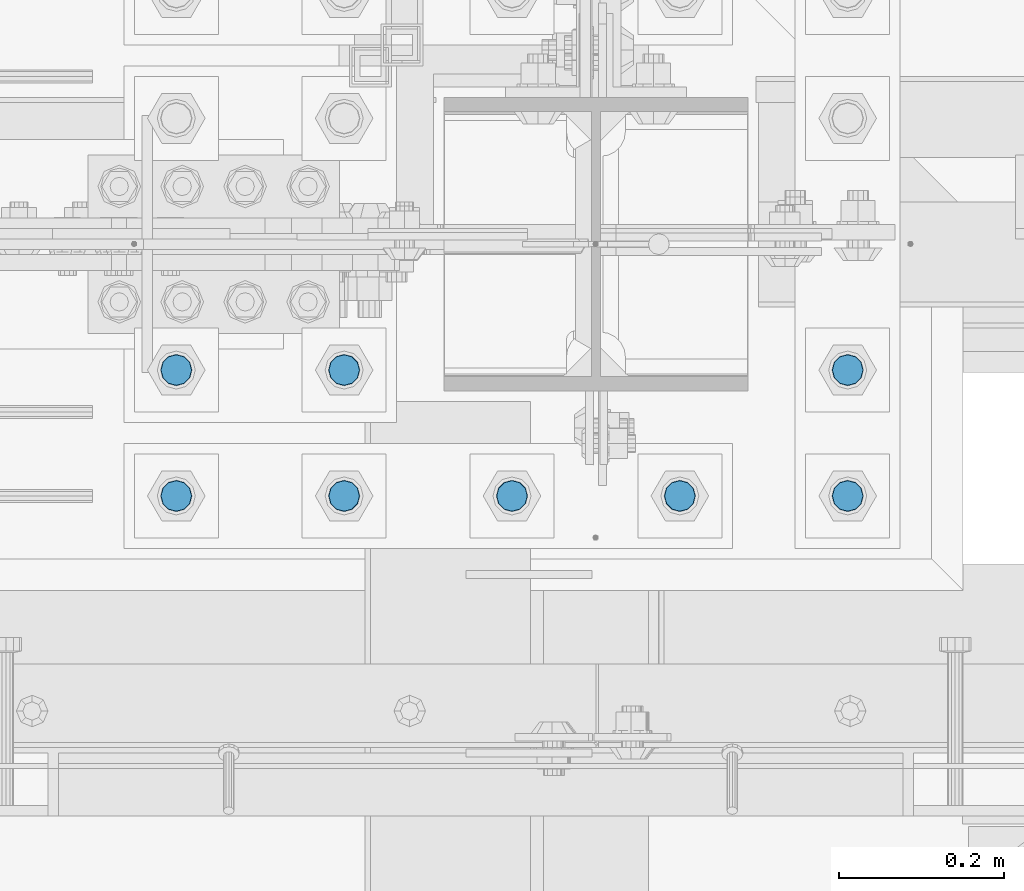
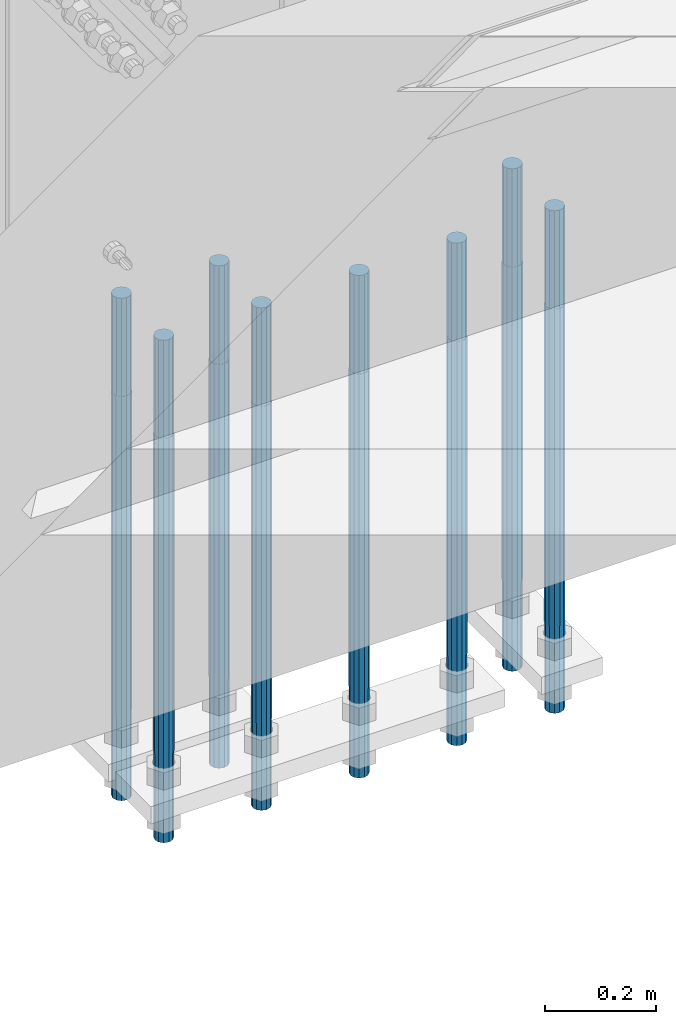
# One storey, part 1299 of 3843: 8 columns, 1 element without a shape of its own.
"""IFC2X3 building model written with IfcOpenShell, lengths in millimetres."""

import ifcopenshell
import ifcopenshell.guid

model = None  # the IFC model being written
_history = None  # IfcOwnerHistory: only IFC2X3 demands one
_inside = {}  # id of a spatial element -> (the spatial element, [elements in it])
_under = {}  # id of a project, library or spatial element -> (it, [spatial elements below it])
_declared = {}  # id of a project -> (the project, [libraries it declares])
_typed = {}  # id of a type object -> (the type object, [elements of that type])
_made_of = {}  # id of a material, layer set ... -> (it, [elements and type objects made of it])


def new_model(schema):
    """Start an empty IFC model of exactly this schema.

    Asked for "IFC4X3", IfcOpenShell would pick the latest addendum, in which some entities
    have other attributes; the version numbers below select the first issue.
    IFC2X3 requires an IfcOwnerHistory on every rooted entity: one is made here for all.
    """
    global model, _history
    if schema == "IFC4X3":
        model = ifcopenshell.file(schema_version=(4, 3, 0, 0))
    else:
        model = ifcopenshell.file(schema=schema)
    _inside.clear()
    _under.clear()
    _declared.clear()
    _typed.clear()
    _made_of.clear()
    _history = None
    if model.schema == "IFC2X3":
        org = make("IfcOrganization", Name="unknown")
        user = make(
            "IfcPersonAndOrganization",
            ThePerson=make("IfcPerson", FamilyName="unknown"),
            TheOrganization=org,
        )
        app = make(
            "IfcApplication",
            ApplicationDeveloper=org,
            Version="unknown",
            ApplicationFullName="unknown",
            ApplicationIdentifier="unknown",
        )
        _history = make(
            "IfcOwnerHistory",
            OwningUser=user,
            OwningApplication=app,
            ChangeAction="ADDED",
            CreationDate=0,
        )
    return model


def make(cls, **values):
    """One entity of the class cls with the attributes given. An attribute that is None is left unset."""
    return model.create_entity(
        cls, **{name: value for name, value in values.items() if value is not None}
    )


def rooted(cls, **values):
    """An entity with a GlobalId (a new one), such as an element, a storey or a relation."""
    return make(cls, GlobalId=ifcopenshell.guid.new(), OwnerHistory=_history, **values)


def si_unit(unit_type, name, prefix=None):
    """IfcSIUnit, for example si_unit("LENGTHUNIT", "METRE", prefix="MILLI")."""
    return make("IfcSIUnit", UnitType=unit_type, Prefix=prefix, Name=name)


def assignment(units):
    """IfcUnitAssignment: the units of a project."""
    return None if units is None else make("IfcUnitAssignment", Units=units)


def point(xyz):
    """IfcCartesianPoint."""
    return None if xyz is None else make("IfcCartesianPoint", Coordinates=xyz)


def direction(xyz):
    """IfcDirection."""
    return None if xyz is None else make("IfcDirection", DirectionRatios=xyz)


def frame(location, z_axis=None, x_axis=None):
    """IfcAxis2Placement3D, a coordinate frame: its origin and axes. An axis left out is left unset."""
    return make(
        "IfcAxis2Placement3D",
        Location=point(location),
        Axis=direction(z_axis),
        RefDirection=direction(x_axis),
    )


def origin_with_axes():
    """The frame at (0, 0, 0) with the z axis (0, 0, 1) and the x axis (1, 0, 0) written out."""
    return frame((0.0, 0.0, 0.0), z_axis=(0.0, 0.0, 1.0), x_axis=(1.0, 0.0, 0.0))


def place(relative_to, where):
    """IfcLocalPlacement: puts the frame where relative to a parent placement (None: the world)."""
    return make(
        "IfcLocalPlacement", PlacementRelTo=relative_to, RelativePlacement=where
    )


def context(
    kind, dimensions, precision=None, world=None, true_north=None, identifier=None
):
    """IfcGeometricRepresentationContext, for example the 3D "Model" context."""
    return make(
        "IfcGeometricRepresentationContext",
        ContextIdentifier=identifier,
        ContextType=kind,
        CoordinateSpaceDimension=dimensions,
        Precision=precision,
        WorldCoordinateSystem=world,
        TrueNorth=true_north,
    )


def subcontext(parent, identifier, kind, view, scale=None):
    """IfcGeometricRepresentationSubContext, for example "Body" below "Model"."""
    return make(
        "IfcGeometricRepresentationSubContext",
        ContextIdentifier=identifier,
        ContextType=kind,
        ParentContext=parent,
        TargetScale=scale,
        TargetView=view,
    )


def project(units=None, contexts=None):
    """IfcProject with its units and contexts."""
    return rooted(
        "IfcProject",
        Name="project",
        RepresentationContexts=contexts,
        UnitsInContext=assignment(units),
    )


def spatial(cls, under=None, at=None, **own):
    """A site, building, storey or space (cls), placed at a placement, below another one or the project."""
    s = rooted(cls, ObjectPlacement=at, **own)
    if under is not None:
        _under.setdefault(under.id(), (under, []))[1].append(s)
    return s


def faces_of(points, faces, orient=None, outer=None):
    """IfcFace entities. A face is a list of loops; a loop is a list of indices into points, from 0.

    orient and outer hold one flag for each loop. By default every Orientation is true, the
    first loop of a face is its IfcFaceOuterBound and the others are IfcFaceBound.
    """
    made = []
    for i, loops in enumerate(faces):
        bounds = []
        for j, loop in enumerate(loops):
            is_outer = j == 0 if outer is None else outer[i][j]
            bounds.append(
                make(
                    "IfcFaceOuterBound" if is_outer else "IfcFaceBound",
                    Bound=make("IfcPolyLoop", Polygon=[points[k] for k in loop]),
                    Orientation=True if orient is None else orient[i][j],
                )
            )
        made.append(make("IfcFace", Bounds=bounds))
    return made


def faceted_brep(points, faces, orient=None, outer=None, voids=None):
    """IfcFacetedBrep: a solid bounded by flat faces; with voids (closed shells), ...WithVoids."""
    shared = [point(p) for p in points]
    hull = make("IfcClosedShell", CfsFaces=faces_of(shared, faces, orient, outer))
    if voids is None:
        return make("IfcFacetedBrep", Outer=hull)
    return make(
        "IfcFacetedBrepWithVoids",
        Outer=hull,
        Voids=[
            make(cls, CfsFaces=faces_of(shared, fs, o, b)) for cls, fs, o, b in voids
        ],
    )


def shape(context_of_items, identifier, shape_type, items):
    """IfcShapeRepresentation: the items that make up one representation, for example the "Body"."""
    return make(
        "IfcShapeRepresentation",
        ContextOfItems=context_of_items,
        RepresentationIdentifier=identifier,
        RepresentationType=shape_type,
        Items=items,
    )


def material(Name=None, Category=None):
    """IfcMaterial."""
    return make("IfcMaterial", Name=Name, Category=Category)


def made_of(thing, what):
    """Note that an element or type object is made of a material, layer set ...; save() writes the relation."""
    if what is not None:
        _made_of.setdefault(what.id(), (what, []))[1].append(thing)
    return thing


def type_object(cls, material=None, **own):
    """A type object (cls), such as IfcWallType, which elements share."""
    return made_of(rooted(cls, **own), material)


def element(
    cls,
    number,
    at=None,
    inside=None,
    cuts=None,
    type_object=None,
    material=None,
    context=None,
    identifier="Body",
    shape_type=None,
    held_by="IfcProductDefinitionShape",
    body=None,
    shapes=None,
    **own,
):
    """One element of the class cls, such as IfcWall. Its Tag is "e" and its number.

    at: its placement. inside: the storey or other place that contains it. cuts: it is an
    opening in that element (IfcRelVoidsElement). A single representation is given by context,
    identifier, shape_type and body (its items); several are given by shapes. held_by: the class
    of the entity that holds the representations. save() writes the other relations.
    """
    e = rooted(cls, Tag="e%d" % number, ObjectPlacement=at, **own)
    if body is not None:
        shapes = [shape(context, identifier, shape_type, body)]
    if shapes is not None:
        e.Representation = make(held_by, Representations=shapes)
    if inside is not None:
        _inside.setdefault(inside.id(), (inside, []))[1].append(e)
    if cuts is not None:
        rooted(
            "IfcRelVoidsElement", RelatingBuildingElement=cuts, RelatedOpeningElement=e
        )
    if type_object is not None:
        _typed.setdefault(type_object.id(), (type_object, []))[1].append(e)
    return made_of(e, material)


def aggregate(whole, parts):
    """IfcRelAggregates: a whole, such as a stair, and the parts it consists of."""
    return rooted("IfcRelAggregates", RelatingObject=whole, RelatedObjects=parts)


def save(model, path):
    """Write the relations noted so far, then the file.

    IfcRelAggregates (storeys below a building ...), IfcRelContainedInSpatialStructure (elements
    in a storey), IfcRelDefinesByType, IfcRelAssociatesMaterial and IfcRelDeclares: one each for
    every whole, place, type object, material and project.
    """
    for whole, parts in _under.values():
        aggregate(whole, parts)
    for where, things in _inside.values():
        rooted(
            "IfcRelContainedInSpatialStructure",
            RelatedElements=things,
            RelatingStructure=where,
        )
    for kind, things in _typed.values():
        rooted("IfcRelDefinesByType", RelatedObjects=things, RelatingType=kind)
    for what, things in _made_of.values():
        rooted("IfcRelAssociatesMaterial", RelatedObjects=things, RelatingMaterial=what)
    for by, libraries in _declared.values():
        rooted("IfcRelDeclares", RelatingContext=by, RelatedDefinitions=libraries)
    model.write(path)


model = new_model("IFC2X3")

# Units and contexts
model_context = context("Model", 3, precision=1e-05, world=origin_with_axes())
body_context = subcontext(model_context, "Body", "Model", "MODEL_VIEW")
ifc_project = project(units=[si_unit("LENGTHUNIT", "METRE", prefix="MILLI"), si_unit("AREAUNIT", "SQUARE_METRE"), si_unit("VOLUMEUNIT", "CUBIC_METRE"), si_unit("MASSUNIT", "GRAM", prefix="KILO"), si_unit("TIMEUNIT", "SECOND"), si_unit("PLANEANGLEUNIT", "RADIAN"), si_unit("SOLIDANGLEUNIT", "STERADIAN"), si_unit("THERMODYNAMICTEMPERATUREUNIT", "DEGREE_CELSIUS"), si_unit("LUMINOUSINTENSITYUNIT", "LUMEN")], contexts=[model_context])

# Site, building, storey
site_placement = place(None, origin_with_axes())
site = spatial("IfcSite", under=ifc_project, at=site_placement, CompositionType="ELEMENT")
building_placement = place(site_placement, origin_with_axes())
building = spatial("IfcBuilding", under=site, at=building_placement, Name="Undefined", CompositionType="ELEMENT")
storey_placement = place(building_placement, origin_with_axes())
storey = spatial("IfcBuildingStorey", under=building, at=storey_placement, Name="Undefined", CompositionType="ELEMENT", Elevation=0.0)

# Assembly, columns
assembly_placement = place(storey_placement, origin_with_axes())
assembly = element("IfcElementAssembly", 1, at=assembly_placement, inside=storey, Name="TEMPLATE", AssemblyPlace="NOTDEFINED", PredefinedType="RIGID_FRAME")
ifc_material = material(Name="Undefined/F1554-GR.55")
column_type = type_object("IfcColumnType", PredefinedType="NOTDEFINED")
column_1_placement = place(assembly_placement, frame((48488.6, 25311.1, 29565.6), z_axis=(0.0, -1.0, 0.0), x_axis=(0.0, 0.0, -1.0)))
column_1 = element("IfcColumn", 2, at=column_1_placement, type_object=column_type, material=ifc_material, Name="ANCHOR_ROD", context=body_context, shape_type="Brep", body=[
    faceted_brep([(-215.899999999998, -16.0214699700118, 9.25), (-215.899999999998, -9.25, 16.0214699700155), (-215.899999999998, 0.0, 18.5), (-215.899999999998, 9.25, 16.0214699700155), (-215.899999999998, 16.0214699700118, 9.25), (-215.899999999998, 18.5, 0.0), (-215.899999999998, 16.0214699700118, -9.25), (-215.899999999998, 9.25, -16.0214699700155), (-215.899999999998, 0.0, -18.5), (-215.899999999998, -9.25, -16.0214699700155), (-215.899999999998, -16.0214699700118, -9.25), (-215.899999999998, -18.5, 0.0), (0.0, 18.5, 0.0), (0.0, 16.0214699700118, -9.25), (0.0, 9.25, -16.0214699700155), (0.0, 0.0, -18.5), (0.0, -9.25, -16.0214699700155), (0.0, -16.0214699700118, -9.25), (0.0, -18.5, 0.0), (0.0, -16.0214699700118, 9.25), (0.0, -9.25, 16.0214699700155), (0.0, 0.0, 18.5), (0.0, 9.25, 16.0214699700155), (0.0, 16.0214699700118, 9.25), (0.0, -16.4977839420972, 9.52500000000146), (0.0, -9.52500000000146, 16.4977839420972), (0.0, 0.0, 19.0499989999989), (0.0, 9.52500000000146, 16.4977839420972), (0.0, 16.4977839420972, 9.52500000000146), (0.0, 19.0500000000029, 0.0), (0.0, 16.4977839420972, -9.52500000000146), (0.0, 9.52500000000146, -16.4977839420972), (0.0, 0.0, -19.0499989999989), (0.0, -9.52500000000146, -16.4977839420972), (0.0, -16.4977839420972, -9.52500000000146), (0.0, -19.0500000000029, 0.0), (698.5, -19.0499999999993, 0.0), (698.5, -16.4977839420935, 9.52499999999418), (698.5, -9.52500000000146, 16.4977839420899), (698.5, 0.0, 19.0500000000029), (698.5, 9.52500000000146, 16.4977839420899), (698.5, 16.4977839420935, 9.52499999999418), (698.5, 19.0499999999993, 0.0), (698.5, 16.4977839420935, -9.52499999999418), (698.5, 9.52500000000146, -16.4977839420899), (698.5, 0.0, -19.0500000000029), (698.5, -9.52500000000146, -16.4977839420899), (698.5, -16.4977839420935, -9.52499999999418), (698.5, -9.25, 16.0214699700155), (698.5, 0.0, 18.5), (698.5, 9.25, 16.0214699700155), (698.5, 16.0214699700118, 9.25), (698.5, 18.5, 0.0), (698.5, 16.0214699700118, -9.25), (698.5, 9.25, -16.0214699700155), (698.5, 0.0, -18.5), (698.5, -9.25, -16.0214699700155), (698.5, -16.0214699700118, -9.25), (698.5, -18.5, 0.0), (698.5, -16.0214699700118, 9.25), (889.0, -9.25, -16.0214699700155), (889.0, 0.0, -18.5), (889.0, 9.25, -16.0214699700155), (889.0, 16.0214699700118, -9.25), (889.0, 18.5, 0.0), (889.0, 16.0214699700118, 9.25), (889.0, 9.25, 16.0214699700155), (889.0, 0.0, 18.5), (889.0, -9.25, 16.0214699700155), (889.0, -16.0214699700118, 9.25), (889.0, -18.5, 0.0), (889.0, -16.0214699700118, -9.25)], [[[0, 1, 2, 3, 4, 5, 6, 7, 8, 9, 10, 11]], [[6, 5, 12, 13]], [[7, 6, 13, 14]], [[8, 7, 14, 15]], [[9, 8, 15, 16]], [[10, 9, 16, 17]], [[11, 10, 17, 18]], [[0, 11, 18, 19]], [[1, 0, 19, 20]], [[2, 1, 20, 21]], [[3, 2, 21, 22]], [[4, 3, 22, 23]], [[5, 4, 23, 12]], [[24, 25, 26, 27, 28, 29, 30, 31, 32, 33, 34, 35], [22, 21, 20, 19, 18, 17, 16, 15, 14, 13, 12, 23]], [[24, 35, 36, 37]], [[25, 24, 37, 38]], [[26, 25, 38, 39]], [[27, 26, 39, 40]], [[28, 27, 40, 41]], [[29, 28, 41, 42]], [[30, 29, 42, 43]], [[31, 30, 43, 44]], [[32, 31, 44, 45]], [[33, 32, 45, 46]], [[34, 33, 46, 47]], [[35, 34, 47, 36]], [[46, 45, 44, 43, 42, 41, 40, 39, 38, 37, 36, 47], [48, 49, 50, 51, 52, 53, 54, 55, 56, 57, 58, 59]], [[60, 61, 62, 63, 64, 65, 66, 67, 68, 69, 70, 71]], [[68, 67, 49, 48]], [[69, 68, 48, 59]], [[70, 69, 59, 58]], [[71, 70, 58, 57]], [[60, 71, 57, 56]], [[61, 60, 56, 55]], [[62, 61, 55, 54]], [[63, 62, 54, 53]], [[64, 63, 53, 52]], [[65, 64, 52, 51]], [[66, 65, 51, 50]], [[67, 66, 50, 49]]]),
])
column_2_placement = place(assembly_placement, frame((48691.8, 25311.1, 29565.6), z_axis=(0.0, -1.0, 0.0), x_axis=(0.0, 0.0, -1.0)))
column_2 = element("IfcColumn", 3, at=column_2_placement, type_object=column_type, material=ifc_material, Name="ANCHOR_ROD", context=body_context, shape_type="Brep", body=[
    faceted_brep([(-215.899999999998, -16.0214699700118, 9.25), (-215.899999999998, -9.25, 16.0214699700155), (-215.899999999998, 0.0, 18.5), (-215.899999999998, 9.25, 16.0214699700155), (-215.899999999998, 16.0214699700118, 9.25), (-215.899999999998, 18.5, 0.0), (-215.899999999998, 16.0214699700118, -9.25), (-215.899999999998, 9.25, -16.0214699700155), (-215.899999999998, 0.0, -18.5), (-215.899999999998, -9.25, -16.0214699700155), (-215.899999999998, -16.0214699700118, -9.25), (-215.899999999998, -18.5, 0.0), (0.0, 18.5, 0.0), (0.0, 16.0214699700118, -9.25), (0.0, 9.25, -16.0214699700155), (0.0, 0.0, -18.5), (0.0, -9.25, -16.0214699700155), (0.0, -16.0214699700118, -9.25), (0.0, -18.5, 0.0), (0.0, -16.0214699700118, 9.25), (0.0, -9.25, 16.0214699700155), (0.0, 0.0, 18.5), (0.0, 9.25, 16.0214699700155), (0.0, 16.0214699700118, 9.25), (0.0, -16.4977839420972, 9.52500000000146), (0.0, -9.52500000000146, 16.4977839420972), (0.0, 0.0, 19.0499989999989), (0.0, 9.52500000000146, 16.4977839420972), (0.0, 16.4977839420972, 9.52500000000146), (0.0, 19.0500000000029, 0.0), (0.0, 16.4977839420972, -9.52500000000146), (0.0, 9.52500000000146, -16.4977839420972), (0.0, 0.0, -19.0499989999989), (0.0, -9.52500000000146, -16.4977839420972), (0.0, -16.4977839420972, -9.52500000000146), (0.0, -19.0500000000029, 0.0), (698.5, -19.0499999999993, 0.0), (698.5, -16.4977839420935, 9.52499999999418), (698.5, -9.52500000000146, 16.4977839420899), (698.5, 0.0, 19.0500000000029), (698.5, 9.52500000000146, 16.4977839420899), (698.5, 16.4977839420935, 9.52499999999418), (698.5, 19.0499999999993, 0.0), (698.5, 16.4977839420935, -9.52499999999418), (698.5, 9.52500000000146, -16.4977839420899), (698.5, 0.0, -19.0500000000029), (698.5, -9.52500000000146, -16.4977839420899), (698.5, -16.4977839420935, -9.52499999999418), (698.5, -9.25, 16.0214699700155), (698.5, 0.0, 18.5), (698.5, 9.25, 16.0214699700155), (698.5, 16.0214699700118, 9.25), (698.5, 18.5, 0.0), (698.5, 16.0214699700118, -9.25), (698.5, 9.25, -16.0214699700155), (698.5, 0.0, -18.5), (698.5, -9.25, -16.0214699700155), (698.5, -16.0214699700118, -9.25), (698.5, -18.5, 0.0), (698.5, -16.0214699700118, 9.25), (889.0, -9.25, -16.0214699700155), (889.0, 0.0, -18.5), (889.0, 9.25, -16.0214699700155), (889.0, 16.0214699700118, -9.25), (889.0, 18.5, 0.0), (889.0, 16.0214699700118, 9.25), (889.0, 9.25, 16.0214699700155), (889.0, 0.0, 18.5), (889.0, -9.25, 16.0214699700155), (889.0, -16.0214699700118, 9.25), (889.0, -18.5, 0.0), (889.0, -16.0214699700118, -9.25)], [[[0, 1, 2, 3, 4, 5, 6, 7, 8, 9, 10, 11]], [[6, 5, 12, 13]], [[7, 6, 13, 14]], [[8, 7, 14, 15]], [[9, 8, 15, 16]], [[10, 9, 16, 17]], [[11, 10, 17, 18]], [[0, 11, 18, 19]], [[1, 0, 19, 20]], [[2, 1, 20, 21]], [[3, 2, 21, 22]], [[4, 3, 22, 23]], [[5, 4, 23, 12]], [[24, 25, 26, 27, 28, 29, 30, 31, 32, 33, 34, 35], [22, 21, 20, 19, 18, 17, 16, 15, 14, 13, 12, 23]], [[24, 35, 36, 37]], [[25, 24, 37, 38]], [[26, 25, 38, 39]], [[27, 26, 39, 40]], [[28, 27, 40, 41]], [[29, 28, 41, 42]], [[30, 29, 42, 43]], [[31, 30, 43, 44]], [[32, 31, 44, 45]], [[33, 32, 45, 46]], [[34, 33, 46, 47]], [[35, 34, 47, 36]], [[46, 45, 44, 43, 42, 41, 40, 39, 38, 37, 36, 47], [48, 49, 50, 51, 52, 53, 54, 55, 56, 57, 58, 59]], [[60, 61, 62, 63, 64, 65, 66, 67, 68, 69, 70, 71]], [[68, 67, 49, 48]], [[69, 68, 48, 59]], [[70, 69, 59, 58]], [[71, 70, 58, 57]], [[60, 71, 57, 56]], [[61, 60, 56, 55]], [[62, 61, 55, 54]], [[63, 62, 54, 53]], [[64, 63, 53, 52]], [[65, 64, 52, 51]], [[66, 65, 51, 50]], [[67, 66, 50, 49]]]),
])
column_3_placement = place(assembly_placement, frame((48895.0, 25311.1, 29565.6), z_axis=(0.0, -1.0, 0.0), x_axis=(0.0, 0.0, -1.0)))
column_3 = element("IfcColumn", 4, at=column_3_placement, type_object=column_type, material=ifc_material, Name="ANCHOR_ROD", context=body_context, shape_type="Brep", body=[
    faceted_brep([(-215.899999999998, -16.0214699700118, 9.25), (-215.899999999998, -9.25, 16.0214699700155), (-215.899999999998, 0.0, 18.5), (-215.899999999998, 9.25, 16.0214699700155), (-215.899999999998, 16.0214699700118, 9.25), (-215.899999999998, 18.5, 0.0), (-215.899999999998, 16.0214699700118, -9.25), (-215.899999999998, 9.25, -16.0214699700155), (-215.899999999998, 0.0, -18.5), (-215.899999999998, -9.25, -16.0214699700155), (-215.899999999998, -16.0214699700118, -9.25), (-215.899999999998, -18.5, 0.0), (0.0, 18.5, 0.0), (0.0, 16.0214699700118, -9.25), (0.0, 9.25, -16.0214699700155), (0.0, 0.0, -18.5), (0.0, -9.25, -16.0214699700155), (0.0, -16.0214699700118, -9.25), (0.0, -18.5, 0.0), (0.0, -16.0214699700118, 9.25), (0.0, -9.25, 16.0214699700155), (0.0, 0.0, 18.5), (0.0, 9.25, 16.0214699700155), (0.0, 16.0214699700118, 9.25), (0.0, -16.4977839420972, 9.52500000000146), (0.0, -9.52500000000146, 16.4977839420972), (0.0, 0.0, 19.0499989999989), (0.0, 9.52500000000146, 16.4977839420972), (0.0, 16.4977839420972, 9.52500000000146), (0.0, 19.0500000000029, 0.0), (0.0, 16.4977839420972, -9.52500000000146), (0.0, 9.52500000000146, -16.4977839420972), (0.0, 0.0, -19.0499989999989), (0.0, -9.52500000000146, -16.4977839420972), (0.0, -16.4977839420972, -9.52500000000146), (0.0, -19.0500000000029, 0.0), (698.5, -19.0499999999993, 0.0), (698.5, -16.4977839420935, 9.52499999999418), (698.5, -9.52500000000146, 16.4977839420899), (698.5, 0.0, 19.0500000000029), (698.5, 9.52500000000146, 16.4977839420899), (698.5, 16.4977839420935, 9.52499999999418), (698.5, 19.0499999999993, 0.0), (698.5, 16.4977839420935, -9.52499999999418), (698.5, 9.52500000000146, -16.4977839420899), (698.5, 0.0, -19.0500000000029), (698.5, -9.52500000000146, -16.4977839420899), (698.5, -16.4977839420935, -9.52499999999418), (698.5, -9.25, 16.0214699700155), (698.5, 0.0, 18.5), (698.5, 9.25, 16.0214699700155), (698.5, 16.0214699700118, 9.25), (698.5, 18.5, 0.0), (698.5, 16.0214699700118, -9.25), (698.5, 9.25, -16.0214699700155), (698.5, 0.0, -18.5), (698.5, -9.25, -16.0214699700155), (698.5, -16.0214699700118, -9.25), (698.5, -18.5, 0.0), (698.5, -16.0214699700118, 9.25), (889.0, -9.25, -16.0214699700155), (889.0, 0.0, -18.5), (889.0, 9.25, -16.0214699700155), (889.0, 16.0214699700118, -9.25), (889.0, 18.5, 0.0), (889.0, 16.0214699700118, 9.25), (889.0, 9.25, 16.0214699700155), (889.0, 0.0, 18.5), (889.0, -9.25, 16.0214699700155), (889.0, -16.0214699700118, 9.25), (889.0, -18.5, 0.0), (889.0, -16.0214699700118, -9.25)], [[[0, 1, 2, 3, 4, 5, 6, 7, 8, 9, 10, 11]], [[6, 5, 12, 13]], [[7, 6, 13, 14]], [[8, 7, 14, 15]], [[9, 8, 15, 16]], [[10, 9, 16, 17]], [[11, 10, 17, 18]], [[0, 11, 18, 19]], [[1, 0, 19, 20]], [[2, 1, 20, 21]], [[3, 2, 21, 22]], [[4, 3, 22, 23]], [[5, 4, 23, 12]], [[24, 25, 26, 27, 28, 29, 30, 31, 32, 33, 34, 35], [22, 21, 20, 19, 18, 17, 16, 15, 14, 13, 12, 23]], [[24, 35, 36, 37]], [[25, 24, 37, 38]], [[26, 25, 38, 39]], [[27, 26, 39, 40]], [[28, 27, 40, 41]], [[29, 28, 41, 42]], [[30, 29, 42, 43]], [[31, 30, 43, 44]], [[32, 31, 44, 45]], [[33, 32, 45, 46]], [[34, 33, 46, 47]], [[35, 34, 47, 36]], [[46, 45, 44, 43, 42, 41, 40, 39, 38, 37, 36, 47], [48, 49, 50, 51, 52, 53, 54, 55, 56, 57, 58, 59]], [[60, 61, 62, 63, 64, 65, 66, 67, 68, 69, 70, 71]], [[68, 67, 49, 48]], [[69, 68, 48, 59]], [[70, 69, 59, 58]], [[71, 70, 58, 57]], [[60, 71, 57, 56]], [[61, 60, 56, 55]], [[62, 61, 55, 54]], [[63, 62, 54, 53]], [[64, 63, 53, 52]], [[65, 64, 52, 51]], [[66, 65, 51, 50]], [[67, 66, 50, 49]]]),
])
column_4_placement = place(assembly_placement, frame((49098.2, 25311.1, 29565.6), z_axis=(0.0, 1.0, 0.0), x_axis=(0.0, 0.0, -1.0)))
column_4 = element("IfcColumn", 5, at=column_4_placement, type_object=column_type, material=ifc_material, Name="ANCHOR_ROD", context=body_context, shape_type="Brep", body=[
    faceted_brep([(-215.899999999998, -16.0214699700118, 9.25), (-215.899999999998, -9.25, 16.0214699700155), (-215.899999999998, 0.0, 18.5), (-215.899999999998, 9.25, 16.0214699700155), (-215.899999999998, 16.0214699700118, 9.25), (-215.899999999998, 18.5, 0.0), (-215.899999999998, 16.0214699700118, -9.25), (-215.899999999998, 9.25, -16.0214699700155), (-215.899999999998, 0.0, -18.5), (-215.899999999998, -9.25, -16.0214699700155), (-215.899999999998, -16.0214699700118, -9.25), (-215.899999999998, -18.5, 0.0), (0.0, 18.5, 0.0), (0.0, 16.0214699700118, -9.25), (0.0, 9.25, -16.0214699700155), (0.0, 0.0, -18.5), (0.0, -9.25, -16.0214699700155), (0.0, -16.0214699700118, -9.25), (0.0, -18.5, 0.0), (0.0, -16.0214699700118, 9.25), (0.0, -9.25, 16.0214699700155), (0.0, 0.0, 18.5), (0.0, 9.25, 16.0214699700155), (0.0, 16.0214699700118, 9.25), (0.0, -16.4977839420972, 9.52500000000146), (0.0, -9.52500000000146, 16.4977839420972), (0.0, 0.0, 19.0499989999989), (0.0, 9.52500000000146, 16.4977839420972), (0.0, 16.4977839420972, 9.52500000000146), (0.0, 19.0500000000029, 0.0), (0.0, 16.4977839420972, -9.52500000000146), (0.0, 9.52500000000146, -16.4977839420972), (0.0, 0.0, -19.0499989999989), (0.0, -9.52500000000146, -16.4977839420972), (0.0, -16.4977839420972, -9.52500000000146), (0.0, -19.0500000000029, 0.0), (698.5, -19.0499999999993, 0.0), (698.5, -16.4977839420935, 9.52499999999418), (698.5, -9.52500000000146, 16.4977839420899), (698.5, 0.0, 19.0500000000029), (698.5, 9.52500000000146, 16.4977839420899), (698.5, 16.4977839420935, 9.52499999999418), (698.5, 19.0499999999993, 0.0), (698.5, 16.4977839420935, -9.52499999999418), (698.5, 9.52500000000146, -16.4977839420899), (698.5, 0.0, -19.0500000000029), (698.5, -9.52500000000146, -16.4977839420899), (698.5, -16.4977839420935, -9.52499999999418), (698.5, -9.25, 16.0214699700155), (698.5, 0.0, 18.5), (698.5, 9.25, 16.0214699700155), (698.5, 16.0214699700118, 9.25), (698.5, 18.5, 0.0), (698.5, 16.0214699700118, -9.25), (698.5, 9.25, -16.0214699700155), (698.5, 0.0, -18.5), (698.5, -9.25, -16.0214699700155), (698.5, -16.0214699700118, -9.25), (698.5, -18.5, 0.0), (698.5, -16.0214699700118, 9.25), (889.0, -9.25, -16.0214699700155), (889.0, 0.0, -18.5), (889.0, 9.25, -16.0214699700155), (889.0, 16.0214699700118, -9.25), (889.0, 18.5, 0.0), (889.0, 16.0214699700118, 9.25), (889.0, 9.25, 16.0214699700155), (889.0, 0.0, 18.5), (889.0, -9.25, 16.0214699700155), (889.0, -16.0214699700118, 9.25), (889.0, -18.5, 0.0), (889.0, -16.0214699700118, -9.25)], [[[0, 1, 2, 3, 4, 5, 6, 7, 8, 9, 10, 11]], [[6, 5, 12, 13]], [[7, 6, 13, 14]], [[8, 7, 14, 15]], [[9, 8, 15, 16]], [[10, 9, 16, 17]], [[11, 10, 17, 18]], [[0, 11, 18, 19]], [[1, 0, 19, 20]], [[2, 1, 20, 21]], [[3, 2, 21, 22]], [[4, 3, 22, 23]], [[5, 4, 23, 12]], [[24, 25, 26, 27, 28, 29, 30, 31, 32, 33, 34, 35], [22, 21, 20, 19, 18, 17, 16, 15, 14, 13, 12, 23]], [[24, 35, 36, 37]], [[25, 24, 37, 38]], [[26, 25, 38, 39]], [[27, 26, 39, 40]], [[28, 27, 40, 41]], [[29, 28, 41, 42]], [[30, 29, 42, 43]], [[31, 30, 43, 44]], [[32, 31, 44, 45]], [[33, 32, 45, 46]], [[34, 33, 46, 47]], [[35, 34, 47, 36]], [[46, 45, 44, 43, 42, 41, 40, 39, 38, 37, 36, 47], [48, 49, 50, 51, 52, 53, 54, 55, 56, 57, 58, 59]], [[60, 61, 62, 63, 64, 65, 66, 67, 68, 69, 70, 71]], [[68, 67, 49, 48]], [[69, 68, 48, 59]], [[70, 69, 59, 58]], [[71, 70, 58, 57]], [[60, 71, 57, 56]], [[61, 60, 56, 55]], [[62, 61, 55, 54]], [[63, 62, 54, 53]], [[64, 63, 53, 52]], [[65, 64, 52, 51]], [[66, 65, 51, 50]], [[67, 66, 50, 49]]]),
])
column_5_placement = place(assembly_placement, frame((49301.4, 25311.1, 29565.6), z_axis=(0.0, 1.0, 0.0), x_axis=(0.0, 0.0, -1.0)))
column_5 = element("IfcColumn", 6, at=column_5_placement, type_object=column_type, material=ifc_material, Name="ANCHOR_ROD", context=body_context, shape_type="Brep", body=[
    faceted_brep([(-215.899999999998, -16.0214699700118, 9.25), (-215.899999999998, -9.25, 16.0214699700155), (-215.899999999998, 0.0, 18.5), (-215.899999999998, 9.25, 16.0214699700155), (-215.899999999998, 16.0214699700118, 9.25), (-215.899999999998, 18.5, 0.0), (-215.899999999998, 16.0214699700118, -9.25), (-215.899999999998, 9.25, -16.0214699700155), (-215.899999999998, 0.0, -18.5), (-215.899999999998, -9.25, -16.0214699700155), (-215.899999999998, -16.0214699700118, -9.25), (-215.899999999998, -18.5, 0.0), (0.0, 18.5, 0.0), (0.0, 16.0214699700118, -9.25), (0.0, 9.25, -16.0214699700155), (0.0, 0.0, -18.5), (0.0, -9.25, -16.0214699700155), (0.0, -16.0214699700118, -9.25), (0.0, -18.5, 0.0), (0.0, -16.0214699700118, 9.25), (0.0, -9.25, 16.0214699700155), (0.0, 0.0, 18.5), (0.0, 9.25, 16.0214699700155), (0.0, 16.0214699700118, 9.25), (0.0, -16.4977839420972, 9.52500000000146), (0.0, -9.52500000000146, 16.4977839420972), (0.0, 0.0, 19.0499989999989), (0.0, 9.52500000000146, 16.4977839420972), (0.0, 16.4977839420972, 9.52500000000146), (0.0, 19.0500000000029, 0.0), (0.0, 16.4977839420972, -9.52500000000146), (0.0, 9.52500000000146, -16.4977839420972), (0.0, 0.0, -19.0499989999989), (0.0, -9.52500000000146, -16.4977839420972), (0.0, -16.4977839420972, -9.52500000000146), (0.0, -19.0500000000029, 0.0), (698.5, -19.0499999999993, 0.0), (698.5, -16.4977839420935, 9.52499999999418), (698.5, -9.52500000000146, 16.4977839420899), (698.5, 0.0, 19.0500000000029), (698.5, 9.52500000000146, 16.4977839420899), (698.5, 16.4977839420935, 9.52499999999418), (698.5, 19.0499999999993, 0.0), (698.5, 16.4977839420935, -9.52499999999418), (698.5, 9.52500000000146, -16.4977839420899), (698.5, 0.0, -19.0500000000029), (698.5, -9.52500000000146, -16.4977839420899), (698.5, -16.4977839420935, -9.52499999999418), (698.5, -9.25, 16.0214699700155), (698.5, 0.0, 18.5), (698.5, 9.25, 16.0214699700155), (698.5, 16.0214699700118, 9.25), (698.5, 18.5, 0.0), (698.5, 16.0214699700118, -9.25), (698.5, 9.25, -16.0214699700155), (698.5, 0.0, -18.5), (698.5, -9.25, -16.0214699700155), (698.5, -16.0214699700118, -9.25), (698.5, -18.5, 0.0), (698.5, -16.0214699700118, 9.25), (889.0, -9.25, -16.0214699700155), (889.0, 0.0, -18.5), (889.0, 9.25, -16.0214699700155), (889.0, 16.0214699700118, -9.25), (889.0, 18.5, 0.0), (889.0, 16.0214699700118, 9.25), (889.0, 9.25, 16.0214699700155), (889.0, 0.0, 18.5), (889.0, -9.25, 16.0214699700155), (889.0, -16.0214699700118, 9.25), (889.0, -18.5, 0.0), (889.0, -16.0214699700118, -9.25)], [[[0, 1, 2, 3, 4, 5, 6, 7, 8, 9, 10, 11]], [[6, 5, 12, 13]], [[7, 6, 13, 14]], [[8, 7, 14, 15]], [[9, 8, 15, 16]], [[10, 9, 16, 17]], [[11, 10, 17, 18]], [[0, 11, 18, 19]], [[1, 0, 19, 20]], [[2, 1, 20, 21]], [[3, 2, 21, 22]], [[4, 3, 22, 23]], [[5, 4, 23, 12]], [[24, 25, 26, 27, 28, 29, 30, 31, 32, 33, 34, 35], [22, 21, 20, 19, 18, 17, 16, 15, 14, 13, 12, 23]], [[24, 35, 36, 37]], [[25, 24, 37, 38]], [[26, 25, 38, 39]], [[27, 26, 39, 40]], [[28, 27, 40, 41]], [[29, 28, 41, 42]], [[30, 29, 42, 43]], [[31, 30, 43, 44]], [[32, 31, 44, 45]], [[33, 32, 45, 46]], [[34, 33, 46, 47]], [[35, 34, 47, 36]], [[46, 45, 44, 43, 42, 41, 40, 39, 38, 37, 36, 47], [48, 49, 50, 51, 52, 53, 54, 55, 56, 57, 58, 59]], [[60, 61, 62, 63, 64, 65, 66, 67, 68, 69, 70, 71]], [[68, 67, 49, 48]], [[69, 68, 48, 59]], [[70, 69, 59, 58]], [[71, 70, 58, 57]], [[60, 71, 57, 56]], [[61, 60, 56, 55]], [[62, 61, 55, 54]], [[63, 62, 54, 53]], [[64, 63, 53, 52]], [[65, 64, 52, 51]], [[66, 65, 51, 50]], [[67, 66, 50, 49]]]),
])
column_6_placement = place(assembly_placement, frame((48488.6, 25463.5, 29565.6), z_axis=(0.0, -1.0, 0.0), x_axis=(0.0, 0.0, -1.0)))
column_6 = element("IfcColumn", 7, at=column_6_placement, type_object=column_type, material=ifc_material, Name="ANCHOR_ROD", context=body_context, shape_type="Brep", body=[
    faceted_brep([(-215.899999999998, -16.0214699700118, 9.25), (-215.899999999998, -9.25, 16.0214699700155), (-215.899999999998, 0.0, 18.5), (-215.899999999998, 9.25, 16.0214699700155), (-215.899999999998, 16.0214699700118, 9.25), (-215.899999999998, 18.5, 0.0), (-215.899999999998, 16.0214699700118, -9.25), (-215.899999999998, 9.25, -16.0214699700155), (-215.899999999998, 0.0, -18.5), (-215.899999999998, -9.25, -16.0214699700155), (-215.899999999998, -16.0214699700118, -9.25), (-215.899999999998, -18.5, 0.0), (0.0, 18.5, 0.0), (0.0, 16.0214699700118, -9.25), (0.0, 9.25, -16.0214699700155), (0.0, 0.0, -18.5), (0.0, -9.25, -16.0214699700155), (0.0, -16.0214699700118, -9.25), (0.0, -18.5, 0.0), (0.0, -16.0214699700118, 9.25), (0.0, -9.25, 16.0214699700155), (0.0, 0.0, 18.5), (0.0, 9.25, 16.0214699700155), (0.0, 16.0214699700118, 9.25), (0.0, -16.4977839420972, 9.52500000000146), (0.0, -9.52500000000146, 16.4977839420972), (0.0, 0.0, 19.0499989999989), (0.0, 9.52500000000146, 16.4977839420972), (0.0, 16.4977839420972, 9.52500000000146), (0.0, 19.0500000000029, 0.0), (0.0, 16.4977839420972, -9.52500000000146), (0.0, 9.52500000000146, -16.4977839420972), (0.0, 0.0, -19.0499989999989), (0.0, -9.52500000000146, -16.4977839420972), (0.0, -16.4977839420972, -9.52500000000146), (0.0, -19.0500000000029, 0.0), (698.5, -19.0499999999993, 0.0), (698.5, -16.4977839420935, 9.52499999999418), (698.5, -9.52500000000146, 16.4977839420899), (698.5, 0.0, 19.0500000000029), (698.5, 9.52500000000146, 16.4977839420899), (698.5, 16.4977839420935, 9.52499999999418), (698.5, 19.0499999999993, 0.0), (698.5, 16.4977839420935, -9.52499999999418), (698.5, 9.52500000000146, -16.4977839420899), (698.5, 0.0, -19.0500000000029), (698.5, -9.52500000000146, -16.4977839420899), (698.5, -16.4977839420935, -9.52499999999418), (698.5, -9.25, 16.0214699700155), (698.5, 0.0, 18.5), (698.5, 9.25, 16.0214699700155), (698.5, 16.0214699700118, 9.25), (698.5, 18.5, 0.0), (698.5, 16.0214699700118, -9.25), (698.5, 9.25, -16.0214699700155), (698.5, 0.0, -18.5), (698.5, -9.25, -16.0214699700155), (698.5, -16.0214699700118, -9.25), (698.5, -18.5, 0.0), (698.5, -16.0214699700118, 9.25), (889.0, -9.25, -16.0214699700155), (889.0, 0.0, -18.5), (889.0, 9.25, -16.0214699700155), (889.0, 16.0214699700118, -9.25), (889.0, 18.5, 0.0), (889.0, 16.0214699700118, 9.25), (889.0, 9.25, 16.0214699700155), (889.0, 0.0, 18.5), (889.0, -9.25, 16.0214699700155), (889.0, -16.0214699700118, 9.25), (889.0, -18.5, 0.0), (889.0, -16.0214699700118, -9.25)], [[[0, 1, 2, 3, 4, 5, 6, 7, 8, 9, 10, 11]], [[6, 5, 12, 13]], [[7, 6, 13, 14]], [[8, 7, 14, 15]], [[9, 8, 15, 16]], [[10, 9, 16, 17]], [[11, 10, 17, 18]], [[0, 11, 18, 19]], [[1, 0, 19, 20]], [[2, 1, 20, 21]], [[3, 2, 21, 22]], [[4, 3, 22, 23]], [[5, 4, 23, 12]], [[24, 25, 26, 27, 28, 29, 30, 31, 32, 33, 34, 35], [22, 21, 20, 19, 18, 17, 16, 15, 14, 13, 12, 23]], [[24, 35, 36, 37]], [[25, 24, 37, 38]], [[26, 25, 38, 39]], [[27, 26, 39, 40]], [[28, 27, 40, 41]], [[29, 28, 41, 42]], [[30, 29, 42, 43]], [[31, 30, 43, 44]], [[32, 31, 44, 45]], [[33, 32, 45, 46]], [[34, 33, 46, 47]], [[35, 34, 47, 36]], [[46, 45, 44, 43, 42, 41, 40, 39, 38, 37, 36, 47], [48, 49, 50, 51, 52, 53, 54, 55, 56, 57, 58, 59]], [[60, 61, 62, 63, 64, 65, 66, 67, 68, 69, 70, 71]], [[68, 67, 49, 48]], [[69, 68, 48, 59]], [[70, 69, 59, 58]], [[71, 70, 58, 57]], [[60, 71, 57, 56]], [[61, 60, 56, 55]], [[62, 61, 55, 54]], [[63, 62, 54, 53]], [[64, 63, 53, 52]], [[65, 64, 52, 51]], [[66, 65, 51, 50]], [[67, 66, 50, 49]]]),
])
column_7_placement = place(assembly_placement, frame((48691.8, 25463.5, 29565.6), z_axis=(0.0, -1.0, 0.0), x_axis=(0.0, 0.0, -1.0)))
column_7 = element("IfcColumn", 8, at=column_7_placement, type_object=column_type, material=ifc_material, Name="ANCHOR_ROD", context=body_context, shape_type="Brep", body=[
    faceted_brep([(-215.899999999998, -16.0214699700118, 9.25), (-215.899999999998, -9.25, 16.0214699700155), (-215.899999999998, 0.0, 18.5), (-215.899999999998, 9.25, 16.0214699700155), (-215.899999999998, 16.0214699700118, 9.25), (-215.899999999998, 18.5, 0.0), (-215.899999999998, 16.0214699700118, -9.25), (-215.899999999998, 9.25, -16.0214699700155), (-215.899999999998, 0.0, -18.5), (-215.899999999998, -9.25, -16.0214699700155), (-215.899999999998, -16.0214699700118, -9.25), (-215.899999999998, -18.5, 0.0), (0.0, 18.5, 0.0), (0.0, 16.0214699700118, -9.25), (0.0, 9.25, -16.0214699700155), (0.0, 0.0, -18.5), (0.0, -9.25, -16.0214699700155), (0.0, -16.0214699700118, -9.25), (0.0, -18.5, 0.0), (0.0, -16.0214699700118, 9.25), (0.0, -9.25, 16.0214699700155), (0.0, 0.0, 18.5), (0.0, 9.25, 16.0214699700155), (0.0, 16.0214699700118, 9.25), (0.0, -16.4977839420972, 9.52500000000146), (0.0, -9.52500000000146, 16.4977839420972), (0.0, 0.0, 19.0499989999989), (0.0, 9.52500000000146, 16.4977839420972), (0.0, 16.4977839420972, 9.52500000000146), (0.0, 19.0500000000029, 0.0), (0.0, 16.4977839420972, -9.52500000000146), (0.0, 9.52500000000146, -16.4977839420972), (0.0, 0.0, -19.0499989999989), (0.0, -9.52500000000146, -16.4977839420972), (0.0, -16.4977839420972, -9.52500000000146), (0.0, -19.0500000000029, 0.0), (698.5, -19.0499999999993, 0.0), (698.5, -16.4977839420935, 9.52499999999418), (698.5, -9.52500000000146, 16.4977839420899), (698.5, 0.0, 19.0500000000029), (698.5, 9.52500000000146, 16.4977839420899), (698.5, 16.4977839420935, 9.52499999999418), (698.5, 19.0499999999993, 0.0), (698.5, 16.4977839420935, -9.52499999999418), (698.5, 9.52500000000146, -16.4977839420899), (698.5, 0.0, -19.0500000000029), (698.5, -9.52500000000146, -16.4977839420899), (698.5, -16.4977839420935, -9.52499999999418), (698.5, -9.25, 16.0214699700155), (698.5, 0.0, 18.5), (698.5, 9.25, 16.0214699700155), (698.5, 16.0214699700118, 9.25), (698.5, 18.5, 0.0), (698.5, 16.0214699700118, -9.25), (698.5, 9.25, -16.0214699700155), (698.5, 0.0, -18.5), (698.5, -9.25, -16.0214699700155), (698.5, -16.0214699700118, -9.25), (698.5, -18.5, 0.0), (698.5, -16.0214699700118, 9.25), (889.0, -9.25, -16.0214699700155), (889.0, 0.0, -18.5), (889.0, 9.25, -16.0214699700155), (889.0, 16.0214699700118, -9.25), (889.0, 18.5, 0.0), (889.0, 16.0214699700118, 9.25), (889.0, 9.25, 16.0214699700155), (889.0, 0.0, 18.5), (889.0, -9.25, 16.0214699700155), (889.0, -16.0214699700118, 9.25), (889.0, -18.5, 0.0), (889.0, -16.0214699700118, -9.25)], [[[0, 1, 2, 3, 4, 5, 6, 7, 8, 9, 10, 11]], [[6, 5, 12, 13]], [[7, 6, 13, 14]], [[8, 7, 14, 15]], [[9, 8, 15, 16]], [[10, 9, 16, 17]], [[11, 10, 17, 18]], [[0, 11, 18, 19]], [[1, 0, 19, 20]], [[2, 1, 20, 21]], [[3, 2, 21, 22]], [[4, 3, 22, 23]], [[5, 4, 23, 12]], [[24, 25, 26, 27, 28, 29, 30, 31, 32, 33, 34, 35], [22, 21, 20, 19, 18, 17, 16, 15, 14, 13, 12, 23]], [[24, 35, 36, 37]], [[25, 24, 37, 38]], [[26, 25, 38, 39]], [[27, 26, 39, 40]], [[28, 27, 40, 41]], [[29, 28, 41, 42]], [[30, 29, 42, 43]], [[31, 30, 43, 44]], [[32, 31, 44, 45]], [[33, 32, 45, 46]], [[34, 33, 46, 47]], [[35, 34, 47, 36]], [[46, 45, 44, 43, 42, 41, 40, 39, 38, 37, 36, 47], [48, 49, 50, 51, 52, 53, 54, 55, 56, 57, 58, 59]], [[60, 61, 62, 63, 64, 65, 66, 67, 68, 69, 70, 71]], [[68, 67, 49, 48]], [[69, 68, 48, 59]], [[70, 69, 59, 58]], [[71, 70, 58, 57]], [[60, 71, 57, 56]], [[61, 60, 56, 55]], [[62, 61, 55, 54]], [[63, 62, 54, 53]], [[64, 63, 53, 52]], [[65, 64, 52, 51]], [[66, 65, 51, 50]], [[67, 66, 50, 49]]]),
])
column_8_placement = place(assembly_placement, frame((49301.4, 25463.5, 29565.6), z_axis=(0.0, 1.0, 0.0), x_axis=(0.0, 0.0, -1.0)))
column_8 = element("IfcColumn", 9, at=column_8_placement, type_object=column_type, material=ifc_material, Name="ANCHOR_ROD", context=body_context, shape_type="Brep", body=[
    faceted_brep([(-215.899999999998, -16.0214699700118, 9.25), (-215.899999999998, -9.25, 16.0214699700155), (-215.899999999998, 0.0, 18.5), (-215.899999999998, 9.25, 16.0214699700155), (-215.899999999998, 16.0214699700118, 9.25), (-215.899999999998, 18.5, 0.0), (-215.899999999998, 16.0214699700118, -9.25), (-215.899999999998, 9.25, -16.0214699700155), (-215.899999999998, 0.0, -18.5), (-215.899999999998, -9.25, -16.0214699700155), (-215.899999999998, -16.0214699700118, -9.25), (-215.899999999998, -18.5, 0.0), (0.0, 18.5, 0.0), (0.0, 16.0214699700118, -9.25), (0.0, 9.25, -16.0214699700155), (0.0, 0.0, -18.5), (0.0, -9.25, -16.0214699700155), (0.0, -16.0214699700118, -9.25), (0.0, -18.5, 0.0), (0.0, -16.0214699700118, 9.25), (0.0, -9.25, 16.0214699700155), (0.0, 0.0, 18.5), (0.0, 9.25, 16.0214699700155), (0.0, 16.0214699700118, 9.25), (0.0, -16.4977839420972, 9.52500000000146), (0.0, -9.52500000000146, 16.4977839420972), (0.0, 0.0, 19.0499989999989), (0.0, 9.52500000000146, 16.4977839420972), (0.0, 16.4977839420972, 9.52500000000146), (0.0, 19.0500000000029, 0.0), (0.0, 16.4977839420972, -9.52500000000146), (0.0, 9.52500000000146, -16.4977839420972), (0.0, 0.0, -19.0499989999989), (0.0, -9.52500000000146, -16.4977839420972), (0.0, -16.4977839420972, -9.52500000000146), (0.0, -19.0500000000029, 0.0), (698.5, -19.0499999999993, 0.0), (698.5, -16.4977839420935, 9.52499999999418), (698.5, -9.52500000000146, 16.4977839420899), (698.5, 0.0, 19.0500000000029), (698.5, 9.52500000000146, 16.4977839420899), (698.5, 16.4977839420935, 9.52499999999418), (698.5, 19.0499999999993, 0.0), (698.5, 16.4977839420935, -9.52499999999418), (698.5, 9.52500000000146, -16.4977839420899), (698.5, 0.0, -19.0500000000029), (698.5, -9.52500000000146, -16.4977839420899), (698.5, -16.4977839420935, -9.52499999999418), (698.5, -9.25, 16.0214699700155), (698.5, 0.0, 18.5), (698.5, 9.25, 16.0214699700155), (698.5, 16.0214699700118, 9.25), (698.5, 18.5, 0.0), (698.5, 16.0214699700118, -9.25), (698.5, 9.25, -16.0214699700155), (698.5, 0.0, -18.5), (698.5, -9.25, -16.0214699700155), (698.5, -16.0214699700118, -9.25), (698.5, -18.5, 0.0), (698.5, -16.0214699700118, 9.25), (889.0, -9.25, -16.0214699700155), (889.0, 0.0, -18.5), (889.0, 9.25, -16.0214699700155), (889.0, 16.0214699700118, -9.25), (889.0, 18.5, 0.0), (889.0, 16.0214699700118, 9.25), (889.0, 9.25, 16.0214699700155), (889.0, 0.0, 18.5), (889.0, -9.25, 16.0214699700155), (889.0, -16.0214699700118, 9.25), (889.0, -18.5, 0.0), (889.0, -16.0214699700118, -9.25)], [[[0, 1, 2, 3, 4, 5, 6, 7, 8, 9, 10, 11]], [[6, 5, 12, 13]], [[7, 6, 13, 14]], [[8, 7, 14, 15]], [[9, 8, 15, 16]], [[10, 9, 16, 17]], [[11, 10, 17, 18]], [[0, 11, 18, 19]], [[1, 0, 19, 20]], [[2, 1, 20, 21]], [[3, 2, 21, 22]], [[4, 3, 22, 23]], [[5, 4, 23, 12]], [[24, 25, 26, 27, 28, 29, 30, 31, 32, 33, 34, 35], [22, 21, 20, 19, 18, 17, 16, 15, 14, 13, 12, 23]], [[24, 35, 36, 37]], [[25, 24, 37, 38]], [[26, 25, 38, 39]], [[27, 26, 39, 40]], [[28, 27, 40, 41]], [[29, 28, 41, 42]], [[30, 29, 42, 43]], [[31, 30, 43, 44]], [[32, 31, 44, 45]], [[33, 32, 45, 46]], [[34, 33, 46, 47]], [[35, 34, 47, 36]], [[46, 45, 44, 43, 42, 41, 40, 39, 38, 37, 36, 47], [48, 49, 50, 51, 52, 53, 54, 55, 56, 57, 58, 59]], [[60, 61, 62, 63, 64, 65, 66, 67, 68, 69, 70, 71]], [[68, 67, 49, 48]], [[69, 68, 48, 59]], [[70, 69, 59, 58]], [[71, 70, 58, 57]], [[60, 71, 57, 56]], [[61, 60, 56, 55]], [[62, 61, 55, 54]], [[63, 62, 54, 53]], [[64, 63, 53, 52]], [[65, 64, 52, 51]], [[66, 65, 51, 50]], [[67, 66, 50, 49]]]),
])
aggregate(assembly, [column_1, column_2, column_3, column_4, column_5, column_6, column_7, column_8])

save(model, "model.ifc")
